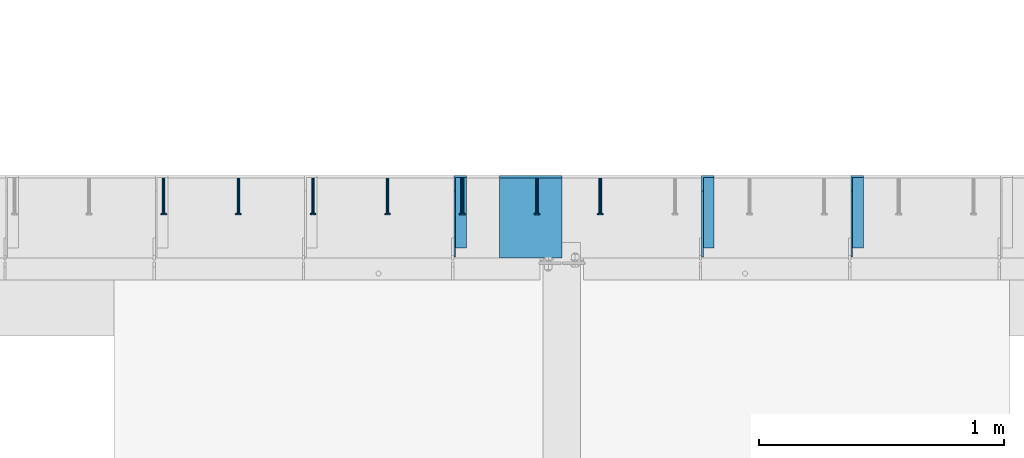
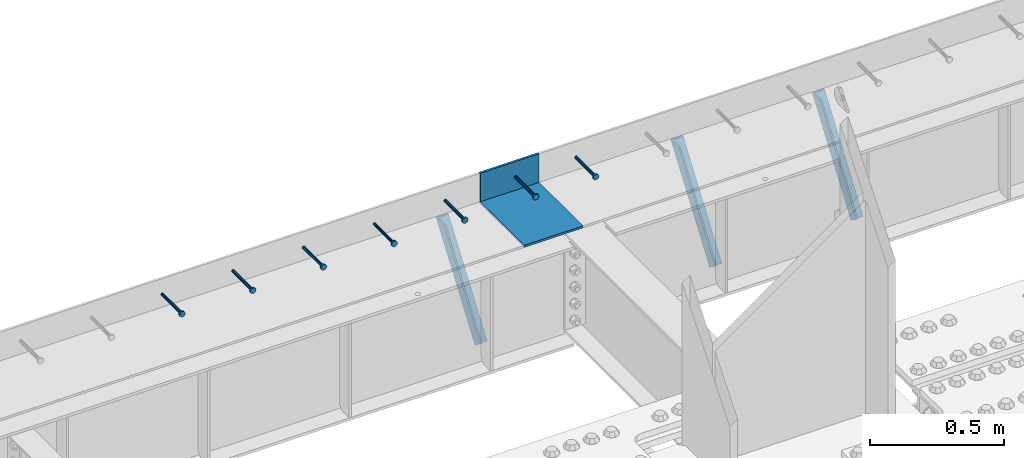
# One storey, part 1341 of 1763: 8 beams, 3 members, 9 elements without a shape of their own.
"""IFC2X3 building model written with IfcOpenShell, lengths in millimetres."""

from ifc_helpers import new_model, si_unit, frame, origin_with_axes, place, context, subcontext, project, spatial, faceted_brep, material, type_object, element, aggregate, save


model = new_model("IFC2X3")

# Units and contexts
model_context = context("Model", 3, precision=1e-05, world=origin_with_axes())
body_context = subcontext(model_context, "Body", "Model", "MODEL_VIEW")
ifc_project = project(units=[si_unit("LENGTHUNIT", "METRE", prefix="MILLI"), si_unit("AREAUNIT", "SQUARE_METRE"), si_unit("VOLUMEUNIT", "CUBIC_METRE"), si_unit("MASSUNIT", "GRAM", prefix="KILO"), si_unit("TIMEUNIT", "SECOND"), si_unit("PLANEANGLEUNIT", "RADIAN"), si_unit("SOLIDANGLEUNIT", "STERADIAN"), si_unit("THERMODYNAMICTEMPERATUREUNIT", "DEGREE_CELSIUS"), si_unit("LUMINOUSINTENSITYUNIT", "LUMEN")], contexts=[model_context])

# Site, building, storey
site_placement = place(None, origin_with_axes())
site = spatial("IfcSite", under=ifc_project, at=site_placement, CompositionType="ELEMENT")
building_placement = place(site_placement, origin_with_axes())
building = spatial("IfcBuilding", under=site, at=building_placement, Name="Undefined", CompositionType="ELEMENT")
storey_placement = place(building_placement, origin_with_axes())
storey = spatial("IfcBuildingStorey", under=building, at=storey_placement, Name="Undefined", CompositionType="ELEMENT", Elevation=0.0)

# Assembly, beam
assembly_1_placement = place(storey_placement, origin_with_axes())
assembly_1 = element("IfcElementAssembly", 1, at=assembly_1_placement, inside=storey, Name="HEADED STUD ANCHOR", AssemblyPlace="NOTDEFINED", PredefinedType="RIGID_FRAME")
ifc_material_1 = material(Name="STEEL/A108")
beam_type_1 = type_object("IfcBeamType", PredefinedType="NOTDEFINED")
beam_1_placement = place(assembly_1_placement, frame((-72333.8747736983, 53984.5250183106, 5264.23140606069), z_axis=(0.0, 0.0, 1.0), x_axis=(0.0, -1.0, 0.0)))
beam_1 = element("IfcBeam", 2, at=beam_1_placement, type_object=beam_type_1, material=ifc_material_1, Name="HEADED STUD ANCHOR", context=body_context, shape_type="Brep", body=[
    faceted_brep([(0.0, -3.1800000667572, 5.5), (0.0, -5.5, 3.1800000667572), (141.732000000002, -5.5, 3.1800000667572), (141.732000000002, -3.1800000667572, 5.5), (0.0, -6.34999999999491, 1.45519152283669e-11), (141.732000000002, -6.34999990463257, 0.0), (0.0, -5.5, -3.1800000667572), (141.732000000002, -5.5, -3.1800000667572), (0.0, -3.1800000667572, -5.5), (141.732000000002, -3.1800000667572, -5.5), (0.0, 0.0, -6.34999990463257), (141.732000000002, 0.0, -6.34999990463257), (0.0, 3.1800000667572, -5.5), (141.732000000002, 3.1800000667572, -5.5), (0.0, 5.5, -3.1800000667572), (141.732000000002, 5.5, -3.1800000667572), (0.0, 6.34999999999491, -2.91038304567337e-11), (141.732000000002, 6.34999990463257, 0.0), (0.0, 5.5, 3.1800000667572), (141.732000000002, 5.5, 3.1800000667572), (0.0, 3.1800000667572, 5.5), (141.732000000002, 3.1800000667572, 5.5), (0.0, 0.0, 6.34999990463257), (141.732000000002, 0.0, 6.34999990463257), (144.780000000001, -10.9899997711182, 6.34999990463257), (144.780000000001, -6.34000015258789, 10.9899997711182), (144.780000000001, -12.6999998092651, 0.0), (144.780000000001, -10.9899997711182, -6.34999990463257), (144.780000000001, -6.34000015258789, -10.9899997711182), (144.780000000001, 0.0, -12.6899995803833), (144.780000000001, 6.34000015258789, -10.9899997711182), (144.780000000001, 10.9899997711182, -6.34999990463257), (144.780000000001, 12.6999998092651, 0.0), (144.780000000001, 10.9899997711182, 6.34999990463257), (144.780000000001, 6.34000015258789, 10.9899997711182), (144.780000000001, 0.0, 12.6899995803833), (152.400000000001, -10.9899997711182, 6.34999990463257), (152.400000000001, -6.34000015258789, 10.9899997711182), (152.400000000001, -12.6999998092651, 0.0), (152.400000000001, -10.9899997711182, -6.34999990463257), (152.400000000001, -6.34000015258789, -10.9899997711182), (152.400000000001, 0.0, -12.6899995803833), (152.400000000001, 6.34000015258789, -10.9899997711182), (152.400000000001, 10.9899997711182, -6.34999990463257), (152.400000000001, 12.6999998092651, 0.0), (152.400000000001, 10.9899997711182, 6.34999990463257), (152.400000000001, 6.34000015258789, 10.9899997711182), (152.400000000001, 0.0, 12.6899995803833)], [[[0, 1, 2, 3]], [[1, 4, 5, 2]], [[4, 6, 7, 5]], [[6, 8, 9, 7]], [[8, 10, 11, 9]], [[10, 12, 13, 11]], [[12, 14, 15, 13]], [[14, 16, 17, 15]], [[16, 18, 19, 17]], [[18, 20, 21, 19]], [[20, 22, 23, 21]], [[22, 0, 3, 23]], [[22, 20, 18, 16, 14, 12, 10, 8, 6, 4, 1, 0]], [[3, 2, 24, 25]], [[2, 5, 26, 24]], [[5, 7, 27, 26]], [[7, 9, 28, 27]], [[9, 11, 29, 28]], [[11, 13, 30, 29]], [[13, 15, 31, 30]], [[15, 17, 32, 31]], [[17, 19, 33, 32]], [[19, 21, 34, 33]], [[21, 23, 35, 34]], [[23, 3, 25, 35]], [[25, 24, 36, 37]], [[24, 26, 38, 36]], [[26, 27, 39, 38]], [[27, 28, 40, 39]], [[28, 29, 41, 40]], [[29, 30, 42, 41]], [[30, 31, 43, 42]], [[31, 32, 44, 43]], [[32, 33, 45, 44]], [[33, 34, 46, 45]], [[34, 35, 47, 46]], [[35, 25, 37, 47]], [[38, 39, 40, 41, 42, 43, 44, 45, 46, 47, 37, 36]]]),
])
aggregate(assembly_1, [beam_1])

assembly_2_placement = place(storey_placement, origin_with_axes())
assembly_2 = element("IfcElementAssembly", 3, at=assembly_2_placement, inside=storey, Name="HEADED STUD ANCHOR", AssemblyPlace="NOTDEFINED", PredefinedType="RIGID_FRAME")
beam_2_placement = place(assembly_2_placement, frame((-72592.6372736983, 53984.5250183106, 5264.23140606069), z_axis=(0.0, 0.0, 1.0), x_axis=(0.0, -1.0, 0.0)))
beam_2 = element("IfcBeam", 4, at=beam_2_placement, type_object=beam_type_1, material=ifc_material_1, Name="HEADED STUD ANCHOR", context=body_context, shape_type="Brep", body=[
    faceted_brep([(0.0, -3.1800000667572, 5.5), (0.0, -5.5, 3.1800000667572), (141.732000000002, -5.5, 3.1800000667572), (141.732000000002, -3.1800000667572, 5.5), (0.0, -6.34999999999491, 1.45519152283669e-11), (141.732000000002, -6.34999990463257, 0.0), (0.0, -5.5, -3.1800000667572), (141.732000000002, -5.5, -3.1800000667572), (0.0, -3.1800000667572, -5.5), (141.732000000002, -3.1800000667572, -5.5), (0.0, 0.0, -6.34999990463257), (141.732000000002, 0.0, -6.34999990463257), (0.0, 3.1800000667572, -5.5), (141.732000000002, 3.1800000667572, -5.5), (0.0, 5.5, -3.1800000667572), (141.732000000002, 5.5, -3.1800000667572), (0.0, 6.34999999999491, -2.91038304567337e-11), (141.732000000002, 6.34999990463257, 0.0), (0.0, 5.5, 3.1800000667572), (141.732000000002, 5.5, 3.1800000667572), (0.0, 3.1800000667572, 5.5), (141.732000000002, 3.1800000667572, 5.5), (0.0, 0.0, 6.34999990463257), (141.732000000002, 0.0, 6.34999990463257), (144.780000000001, -10.9899997711182, 6.34999990463257), (144.780000000001, -6.34000015258789, 10.9899997711182), (144.780000000001, -12.6999998092651, 0.0), (144.780000000001, -10.9899997711182, -6.34999990463257), (144.780000000001, -6.34000015258789, -10.9899997711182), (144.780000000001, 0.0, -12.6899995803833), (144.780000000001, 6.34000015258789, -10.9899997711182), (144.780000000001, 10.9899997711182, -6.34999990463257), (144.780000000001, 12.6999998092651, 0.0), (144.780000000001, 10.9899997711182, 6.34999990463257), (144.780000000001, 6.34000015258789, 10.9899997711182), (144.780000000001, 0.0, 12.6899995803833), (152.400000000001, -10.9899997711182, 6.34999990463257), (152.400000000001, -6.34000015258789, 10.9899997711182), (152.400000000001, -12.6999998092651, 0.0), (152.400000000001, -10.9899997711182, -6.34999990463257), (152.400000000001, -6.34000015258789, -10.9899997711182), (152.400000000001, 0.0, -12.6899995803833), (152.400000000001, 6.34000015258789, -10.9899997711182), (152.400000000001, 10.9899997711182, -6.34999990463257), (152.400000000001, 12.6999998092651, 0.0), (152.400000000001, 10.9899997711182, 6.34999990463257), (152.400000000001, 6.34000015258789, 10.9899997711182), (152.400000000001, 0.0, 12.6899995803833)], [[[0, 1, 2, 3]], [[1, 4, 5, 2]], [[4, 6, 7, 5]], [[6, 8, 9, 7]], [[8, 10, 11, 9]], [[10, 12, 13, 11]], [[12, 14, 15, 13]], [[14, 16, 17, 15]], [[16, 18, 19, 17]], [[18, 20, 21, 19]], [[20, 22, 23, 21]], [[22, 0, 3, 23]], [[22, 20, 18, 16, 14, 12, 10, 8, 6, 4, 1, 0]], [[3, 2, 24, 25]], [[2, 5, 26, 24]], [[5, 7, 27, 26]], [[7, 9, 28, 27]], [[9, 11, 29, 28]], [[11, 13, 30, 29]], [[13, 15, 31, 30]], [[15, 17, 32, 31]], [[17, 19, 33, 32]], [[19, 21, 34, 33]], [[21, 23, 35, 34]], [[23, 3, 25, 35]], [[25, 24, 36, 37]], [[24, 26, 38, 36]], [[26, 27, 39, 38]], [[27, 28, 40, 39]], [[28, 29, 41, 40]], [[29, 30, 42, 41]], [[30, 31, 43, 42]], [[31, 32, 44, 43]], [[32, 33, 45, 44]], [[33, 34, 46, 45]], [[34, 35, 47, 46]], [[35, 25, 37, 47]], [[38, 39, 40, 41, 42, 43, 44, 45, 46, 47, 37, 36]]]),
])
aggregate(assembly_2, [beam_2])

assembly_3_placement = place(storey_placement, origin_with_axes())
assembly_3 = element("IfcElementAssembly", 5, at=assembly_3_placement, inside=storey, Name="HEADED STUD ANCHOR", AssemblyPlace="NOTDEFINED", PredefinedType="RIGID_FRAME")
beam_3_placement = place(assembly_3_placement, frame((-72897.4372736983, 53984.5250183106, 5264.23140606069), z_axis=(0.0, 0.0, 1.0), x_axis=(0.0, -1.0, 0.0)))
beam_3 = element("IfcBeam", 6, at=beam_3_placement, type_object=beam_type_1, material=ifc_material_1, Name="HEADED STUD ANCHOR", context=body_context, shape_type="Brep", body=[
    faceted_brep([(0.0, -3.1800000667572, 5.5), (0.0, -5.5, 3.1800000667572), (141.732000000002, -5.5, 3.1800000667572), (141.732000000002, -3.1800000667572, 5.5), (0.0, -6.34999999999491, 1.45519152283669e-11), (141.732000000002, -6.34999990463257, 0.0), (0.0, -5.5, -3.1800000667572), (141.732000000002, -5.5, -3.1800000667572), (0.0, -3.1800000667572, -5.5), (141.732000000002, -3.1800000667572, -5.5), (0.0, 0.0, -6.34999990463257), (141.732000000002, 0.0, -6.34999990463257), (0.0, 3.1800000667572, -5.5), (141.732000000002, 3.1800000667572, -5.5), (0.0, 5.5, -3.1800000667572), (141.732000000002, 5.5, -3.1800000667572), (0.0, 6.34999999999491, -2.91038304567337e-11), (141.732000000002, 6.34999990463257, 0.0), (0.0, 5.5, 3.1800000667572), (141.732000000002, 5.5, 3.1800000667572), (0.0, 3.1800000667572, 5.5), (141.732000000002, 3.1800000667572, 5.5), (0.0, 0.0, 6.34999990463257), (141.732000000002, 0.0, 6.34999990463257), (144.780000000001, -10.9899997711182, 6.34999990463257), (144.780000000001, -6.34000015258789, 10.9899997711182), (144.780000000001, -12.6999998092651, 0.0), (144.780000000001, -10.9899997711182, -6.34999990463257), (144.780000000001, -6.34000015258789, -10.9899997711182), (144.780000000001, 0.0, -12.6899995803833), (144.780000000001, 6.34000015258789, -10.9899997711182), (144.780000000001, 10.9899997711182, -6.34999990463257), (144.780000000001, 12.6999998092651, 0.0), (144.780000000001, 10.9899997711182, 6.34999990463257), (144.780000000001, 6.34000015258789, 10.9899997711182), (144.780000000001, 0.0, 12.6899995803833), (152.400000000001, -10.9899997711182, 6.34999990463257), (152.400000000001, -6.34000015258789, 10.9899997711182), (152.400000000001, -12.6999998092651, 0.0), (152.400000000001, -10.9899997711182, -6.34999990463257), (152.400000000001, -6.34000015258789, -10.9899997711182), (152.400000000001, 0.0, -12.6899995803833), (152.400000000001, 6.34000015258789, -10.9899997711182), (152.400000000001, 10.9899997711182, -6.34999990463257), (152.400000000001, 12.6999998092651, 0.0), (152.400000000001, 10.9899997711182, 6.34999990463257), (152.400000000001, 6.34000015258789, 10.9899997711182), (152.400000000001, 0.0, 12.6899995803833)], [[[0, 1, 2, 3]], [[1, 4, 5, 2]], [[4, 6, 7, 5]], [[6, 8, 9, 7]], [[8, 10, 11, 9]], [[10, 12, 13, 11]], [[12, 14, 15, 13]], [[14, 16, 17, 15]], [[16, 18, 19, 17]], [[18, 20, 21, 19]], [[20, 22, 23, 21]], [[22, 0, 3, 23]], [[22, 20, 18, 16, 14, 12, 10, 8, 6, 4, 1, 0]], [[3, 2, 24, 25]], [[2, 5, 26, 24]], [[5, 7, 27, 26]], [[7, 9, 28, 27]], [[9, 11, 29, 28]], [[11, 13, 30, 29]], [[13, 15, 31, 30]], [[15, 17, 32, 31]], [[17, 19, 33, 32]], [[19, 21, 34, 33]], [[21, 23, 35, 34]], [[23, 3, 25, 35]], [[25, 24, 36, 37]], [[24, 26, 38, 36]], [[26, 27, 39, 38]], [[27, 28, 40, 39]], [[28, 29, 41, 40]], [[29, 30, 42, 41]], [[30, 31, 43, 42]], [[31, 32, 44, 43]], [[32, 33, 45, 44]], [[33, 34, 46, 45]], [[34, 35, 47, 46]], [[35, 25, 37, 47]], [[38, 39, 40, 41, 42, 43, 44, 45, 46, 47, 37, 36]]]),
])
aggregate(assembly_3, [beam_3])

assembly_4_placement = place(storey_placement, origin_with_axes())
assembly_4 = element("IfcElementAssembly", 7, at=assembly_4_placement, inside=storey, Name="HEADED STUD ANCHOR", AssemblyPlace="NOTDEFINED", PredefinedType="RIGID_FRAME")
beam_4_placement = place(assembly_4_placement, frame((-73202.2372736984, 53984.5250183106, 5264.23140606069), z_axis=(0.0, 0.0, 1.0), x_axis=(0.0, -1.0, 0.0)))
beam_4 = element("IfcBeam", 8, at=beam_4_placement, type_object=beam_type_1, material=ifc_material_1, Name="HEADED STUD ANCHOR", context=body_context, shape_type="Brep", body=[
    faceted_brep([(0.0, -3.1800000667572, 5.5), (0.0, -5.5, 3.1800000667572), (141.732000000002, -5.5, 3.1800000667572), (141.732000000002, -3.1800000667572, 5.5), (0.0, -6.34999999999491, 1.45519152283669e-11), (141.732000000002, -6.34999990463257, 0.0), (0.0, -5.5, -3.1800000667572), (141.732000000002, -5.5, -3.1800000667572), (0.0, -3.1800000667572, -5.5), (141.732000000002, -3.1800000667572, -5.5), (0.0, 0.0, -6.34999990463257), (141.732000000002, 0.0, -6.34999990463257), (0.0, 3.1800000667572, -5.5), (141.732000000002, 3.1800000667572, -5.5), (0.0, 5.5, -3.1800000667572), (141.732000000002, 5.5, -3.1800000667572), (0.0, 6.34999999999491, -2.91038304567337e-11), (141.732000000002, 6.34999990463257, 0.0), (0.0, 5.5, 3.1800000667572), (141.732000000002, 5.5, 3.1800000667572), (0.0, 3.1800000667572, 5.5), (141.732000000002, 3.1800000667572, 5.5), (0.0, 0.0, 6.34999990463257), (141.732000000002, 0.0, 6.34999990463257), (144.780000000001, -10.9899997711182, 6.34999990463257), (144.780000000001, -6.34000015258789, 10.9899997711182), (144.780000000001, -12.6999998092651, 0.0), (144.780000000001, -10.9899997711182, -6.34999990463257), (144.780000000001, -6.34000015258789, -10.9899997711182), (144.780000000001, 0.0, -12.6899995803833), (144.780000000001, 6.34000015258789, -10.9899997711182), (144.780000000001, 10.9899997711182, -6.34999990463257), (144.780000000001, 12.6999998092651, 0.0), (144.780000000001, 10.9899997711182, 6.34999990463257), (144.780000000001, 6.34000015258789, 10.9899997711182), (144.780000000001, 0.0, 12.6899995803833), (152.400000000001, -10.9899997711182, 6.34999990463257), (152.400000000001, -6.34000015258789, 10.9899997711182), (152.400000000001, -12.6999998092651, 0.0), (152.400000000001, -10.9899997711182, -6.34999990463257), (152.400000000001, -6.34000015258789, -10.9899997711182), (152.400000000001, 0.0, -12.6899995803833), (152.400000000001, 6.34000015258789, -10.9899997711182), (152.400000000001, 10.9899997711182, -6.34999990463257), (152.400000000001, 12.6999998092651, 0.0), (152.400000000001, 10.9899997711182, 6.34999990463257), (152.400000000001, 6.34000015258789, 10.9899997711182), (152.400000000001, 0.0, 12.6899995803833)], [[[0, 1, 2, 3]], [[1, 4, 5, 2]], [[4, 6, 7, 5]], [[6, 8, 9, 7]], [[8, 10, 11, 9]], [[10, 12, 13, 11]], [[12, 14, 15, 13]], [[14, 16, 17, 15]], [[16, 18, 19, 17]], [[18, 20, 21, 19]], [[20, 22, 23, 21]], [[22, 0, 3, 23]], [[22, 20, 18, 16, 14, 12, 10, 8, 6, 4, 1, 0]], [[3, 2, 24, 25]], [[2, 5, 26, 24]], [[5, 7, 27, 26]], [[7, 9, 28, 27]], [[9, 11, 29, 28]], [[11, 13, 30, 29]], [[13, 15, 31, 30]], [[15, 17, 32, 31]], [[17, 19, 33, 32]], [[19, 21, 34, 33]], [[21, 23, 35, 34]], [[23, 3, 25, 35]], [[25, 24, 36, 37]], [[24, 26, 38, 36]], [[26, 27, 39, 38]], [[27, 28, 40, 39]], [[28, 29, 41, 40]], [[29, 30, 42, 41]], [[30, 31, 43, 42]], [[31, 32, 44, 43]], [[32, 33, 45, 44]], [[33, 34, 46, 45]], [[34, 35, 47, 46]], [[35, 25, 37, 47]], [[38, 39, 40, 41, 42, 43, 44, 45, 46, 47, 37, 36]]]),
])
aggregate(assembly_4, [beam_4])

assembly_5_placement = place(storey_placement, origin_with_axes())
assembly_5 = element("IfcElementAssembly", 9, at=assembly_5_placement, inside=storey, Name="HEADED STUD ANCHOR", AssemblyPlace="NOTDEFINED", PredefinedType="RIGID_FRAME")
beam_5_placement = place(assembly_5_placement, frame((-73507.0372736983, 53984.5250183106, 5264.23140606069), z_axis=(0.0, 0.0, 1.0), x_axis=(0.0, -1.0, 0.0)))
beam_5 = element("IfcBeam", 10, at=beam_5_placement, type_object=beam_type_1, material=ifc_material_1, Name="HEADED STUD ANCHOR", context=body_context, shape_type="Brep", body=[
    faceted_brep([(0.0, -3.1800000667572, 5.5), (0.0, -5.5, 3.1800000667572), (141.732000000002, -5.5, 3.1800000667572), (141.732000000002, -3.1800000667572, 5.5), (0.0, -6.34999999999491, 1.45519152283669e-11), (141.732000000002, -6.34999990463257, 0.0), (0.0, -5.5, -3.1800000667572), (141.732000000002, -5.5, -3.1800000667572), (0.0, -3.1800000667572, -5.5), (141.732000000002, -3.1800000667572, -5.5), (0.0, 0.0, -6.34999990463257), (141.732000000002, 0.0, -6.34999990463257), (0.0, 3.1800000667572, -5.5), (141.732000000002, 3.1800000667572, -5.5), (0.0, 5.5, -3.1800000667572), (141.732000000002, 5.5, -3.1800000667572), (0.0, 6.34999999999491, -2.91038304567337e-11), (141.732000000002, 6.34999990463257, 0.0), (0.0, 5.5, 3.1800000667572), (141.732000000002, 5.5, 3.1800000667572), (0.0, 3.1800000667572, 5.5), (141.732000000002, 3.1800000667572, 5.5), (0.0, 0.0, 6.34999990463257), (141.732000000002, 0.0, 6.34999990463257), (144.780000000001, -10.9899997711182, 6.34999990463257), (144.780000000001, -6.34000015258789, 10.9899997711182), (144.780000000001, -12.6999998092651, 0.0), (144.780000000001, -10.9899997711182, -6.34999990463257), (144.780000000001, -6.34000015258789, -10.9899997711182), (144.780000000001, 0.0, -12.6899995803833), (144.780000000001, 6.34000015258789, -10.9899997711182), (144.780000000001, 10.9899997711182, -6.34999990463257), (144.780000000001, 12.6999998092651, 0.0), (144.780000000001, 10.9899997711182, 6.34999990463257), (144.780000000001, 6.34000015258789, 10.9899997711182), (144.780000000001, 0.0, 12.6899995803833), (152.400000000001, -10.9899997711182, 6.34999990463257), (152.400000000001, -6.34000015258789, 10.9899997711182), (152.400000000001, -12.6999998092651, 0.0), (152.400000000001, -10.9899997711182, -6.34999990463257), (152.400000000001, -6.34000015258789, -10.9899997711182), (152.400000000001, 0.0, -12.6899995803833), (152.400000000001, 6.34000015258789, -10.9899997711182), (152.400000000001, 10.9899997711182, -6.34999990463257), (152.400000000001, 12.6999998092651, 0.0), (152.400000000001, 10.9899997711182, 6.34999990463257), (152.400000000001, 6.34000015258789, 10.9899997711182), (152.400000000001, 0.0, 12.6899995803833)], [[[0, 1, 2, 3]], [[1, 4, 5, 2]], [[4, 6, 7, 5]], [[6, 8, 9, 7]], [[8, 10, 11, 9]], [[10, 12, 13, 11]], [[12, 14, 15, 13]], [[14, 16, 17, 15]], [[16, 18, 19, 17]], [[18, 20, 21, 19]], [[20, 22, 23, 21]], [[22, 0, 3, 23]], [[22, 20, 18, 16, 14, 12, 10, 8, 6, 4, 1, 0]], [[3, 2, 24, 25]], [[2, 5, 26, 24]], [[5, 7, 27, 26]], [[7, 9, 28, 27]], [[9, 11, 29, 28]], [[11, 13, 30, 29]], [[13, 15, 31, 30]], [[15, 17, 32, 31]], [[17, 19, 33, 32]], [[19, 21, 34, 33]], [[21, 23, 35, 34]], [[23, 3, 25, 35]], [[25, 24, 36, 37]], [[24, 26, 38, 36]], [[26, 27, 39, 38]], [[27, 28, 40, 39]], [[28, 29, 41, 40]], [[29, 30, 42, 41]], [[30, 31, 43, 42]], [[31, 32, 44, 43]], [[32, 33, 45, 44]], [[33, 34, 46, 45]], [[34, 35, 47, 46]], [[35, 25, 37, 47]], [[38, 39, 40, 41, 42, 43, 44, 45, 46, 47, 37, 36]]]),
])
aggregate(assembly_5, [beam_5])

assembly_6_placement = place(storey_placement, origin_with_axes())
assembly_6 = element("IfcElementAssembly", 11, at=assembly_6_placement, inside=storey, Name="HEADED STUD ANCHOR", AssemblyPlace="NOTDEFINED", PredefinedType="RIGID_FRAME")
beam_6_placement = place(assembly_6_placement, frame((-73811.8372736983, 53984.5250183106, 5264.23140606069), z_axis=(0.0, 0.0, 1.0), x_axis=(0.0, -1.0, 0.0)))
beam_6 = element("IfcBeam", 12, at=beam_6_placement, type_object=beam_type_1, material=ifc_material_1, Name="HEADED STUD ANCHOR", context=body_context, shape_type="Brep", body=[
    faceted_brep([(0.0, -3.1800000667572, 5.5), (0.0, -5.5, 3.1800000667572), (141.732000000002, -5.5, 3.1800000667572), (141.732000000002, -3.1800000667572, 5.5), (0.0, -6.34999999999491, 1.45519152283669e-11), (141.732000000002, -6.34999990463257, 0.0), (0.0, -5.5, -3.1800000667572), (141.732000000002, -5.5, -3.1800000667572), (0.0, -3.1800000667572, -5.5), (141.732000000002, -3.1800000667572, -5.5), (0.0, 0.0, -6.34999990463257), (141.732000000002, 0.0, -6.34999990463257), (0.0, 3.1800000667572, -5.5), (141.732000000002, 3.1800000667572, -5.5), (0.0, 5.5, -3.1800000667572), (141.732000000002, 5.5, -3.1800000667572), (0.0, 6.34999999999491, -2.91038304567337e-11), (141.732000000002, 6.34999990463257, 0.0), (0.0, 5.5, 3.1800000667572), (141.732000000002, 5.5, 3.1800000667572), (0.0, 3.1800000667572, 5.5), (141.732000000002, 3.1800000667572, 5.5), (0.0, 0.0, 6.34999990463257), (141.732000000002, 0.0, 6.34999990463257), (144.780000000001, -10.9899997711182, 6.34999990463257), (144.780000000001, -6.34000015258789, 10.9899997711182), (144.780000000001, -12.6999998092651, 0.0), (144.780000000001, -10.9899997711182, -6.34999990463257), (144.780000000001, -6.34000015258789, -10.9899997711182), (144.780000000001, 0.0, -12.6899995803833), (144.780000000001, 6.34000015258789, -10.9899997711182), (144.780000000001, 10.9899997711182, -6.34999990463257), (144.780000000001, 12.6999998092651, 0.0), (144.780000000001, 10.9899997711182, 6.34999990463257), (144.780000000001, 6.34000015258789, 10.9899997711182), (144.780000000001, 0.0, 12.6899995803833), (152.400000000001, -10.9899997711182, 6.34999990463257), (152.400000000001, -6.34000015258789, 10.9899997711182), (152.400000000001, -12.6999998092651, 0.0), (152.400000000001, -10.9899997711182, -6.34999990463257), (152.400000000001, -6.34000015258789, -10.9899997711182), (152.400000000001, 0.0, -12.6899995803833), (152.400000000001, 6.34000015258789, -10.9899997711182), (152.400000000001, 10.9899997711182, -6.34999990463257), (152.400000000001, 12.6999998092651, 0.0), (152.400000000001, 10.9899997711182, 6.34999990463257), (152.400000000001, 6.34000015258789, 10.9899997711182), (152.400000000001, 0.0, 12.6899995803833)], [[[0, 1, 2, 3]], [[1, 4, 5, 2]], [[4, 6, 7, 5]], [[6, 8, 9, 7]], [[8, 10, 11, 9]], [[10, 12, 13, 11]], [[12, 14, 15, 13]], [[14, 16, 17, 15]], [[16, 18, 19, 17]], [[18, 20, 21, 19]], [[20, 22, 23, 21]], [[22, 0, 3, 23]], [[22, 20, 18, 16, 14, 12, 10, 8, 6, 4, 1, 0]], [[3, 2, 24, 25]], [[2, 5, 26, 24]], [[5, 7, 27, 26]], [[7, 9, 28, 27]], [[9, 11, 29, 28]], [[11, 13, 30, 29]], [[13, 15, 31, 30]], [[15, 17, 32, 31]], [[17, 19, 33, 32]], [[19, 21, 34, 33]], [[21, 23, 35, 34]], [[23, 3, 25, 35]], [[25, 24, 36, 37]], [[24, 26, 38, 36]], [[26, 27, 39, 38]], [[27, 28, 40, 39]], [[28, 29, 41, 40]], [[29, 30, 42, 41]], [[30, 31, 43, 42]], [[31, 32, 44, 43]], [[32, 33, 45, 44]], [[33, 34, 46, 45]], [[34, 35, 47, 46]], [[35, 25, 37, 47]], [[38, 39, 40, 41, 42, 43, 44, 45, 46, 47, 37, 36]]]),
])
aggregate(assembly_6, [beam_6])

assembly_7_placement = place(storey_placement, origin_with_axes())
assembly_7 = element("IfcElementAssembly", 13, at=assembly_7_placement, inside=storey, Name="HEADED STUD ANCHOR", AssemblyPlace="NOTDEFINED", PredefinedType="RIGID_FRAME")
beam_7_placement = place(assembly_7_placement, frame((-74116.6372736983, 53984.5250183106, 5264.23140606069), z_axis=(0.0, 0.0, 1.0), x_axis=(0.0, -1.0, 0.0)))
beam_7 = element("IfcBeam", 14, at=beam_7_placement, type_object=beam_type_1, material=ifc_material_1, Name="HEADED STUD ANCHOR", context=body_context, shape_type="Brep", body=[
    faceted_brep([(0.0, -3.1800000667572, 5.5), (0.0, -5.5, 3.1800000667572), (141.732000000002, -5.5, 3.1800000667572), (141.732000000002, -3.1800000667572, 5.5), (0.0, -6.34999999999491, 1.45519152283669e-11), (141.732000000002, -6.34999990463257, 0.0), (0.0, -5.5, -3.1800000667572), (141.732000000002, -5.5, -3.1800000667572), (0.0, -3.1800000667572, -5.5), (141.732000000002, -3.1800000667572, -5.5), (0.0, 0.0, -6.34999990463257), (141.732000000002, 0.0, -6.34999990463257), (0.0, 3.1800000667572, -5.5), (141.732000000002, 3.1800000667572, -5.5), (0.0, 5.5, -3.1800000667572), (141.732000000002, 5.5, -3.1800000667572), (0.0, 6.34999999999491, -2.91038304567337e-11), (141.732000000002, 6.34999990463257, 0.0), (0.0, 5.5, 3.1800000667572), (141.732000000002, 5.5, 3.1800000667572), (0.0, 3.1800000667572, 5.5), (141.732000000002, 3.1800000667572, 5.5), (0.0, 0.0, 6.34999990463257), (141.732000000002, 0.0, 6.34999990463257), (144.780000000001, -10.9899997711182, 6.34999990463257), (144.780000000001, -6.34000015258789, 10.9899997711182), (144.780000000001, -12.6999998092651, 0.0), (144.780000000001, -10.9899997711182, -6.34999990463257), (144.780000000001, -6.34000015258789, -10.9899997711182), (144.780000000001, 0.0, -12.6899995803833), (144.780000000001, 6.34000015258789, -10.9899997711182), (144.780000000001, 10.9899997711182, -6.34999990463257), (144.780000000001, 12.6999998092651, 0.0), (144.780000000001, 10.9899997711182, 6.34999990463257), (144.780000000001, 6.34000015258789, 10.9899997711182), (144.780000000001, 0.0, 12.6899995803833), (152.400000000001, -10.9899997711182, 6.34999990463257), (152.400000000001, -6.34000015258789, 10.9899997711182), (152.400000000001, -12.6999998092651, 0.0), (152.400000000001, -10.9899997711182, -6.34999990463257), (152.400000000001, -6.34000015258789, -10.9899997711182), (152.400000000001, 0.0, -12.6899995803833), (152.400000000001, 6.34000015258789, -10.9899997711182), (152.400000000001, 10.9899997711182, -6.34999990463257), (152.400000000001, 12.6999998092651, 0.0), (152.400000000001, 10.9899997711182, 6.34999990463257), (152.400000000001, 6.34000015258789, 10.9899997711182), (152.400000000001, 0.0, 12.6899995803833)], [[[0, 1, 2, 3]], [[1, 4, 5, 2]], [[4, 6, 7, 5]], [[6, 8, 9, 7]], [[8, 10, 11, 9]], [[10, 12, 13, 11]], [[12, 14, 15, 13]], [[14, 16, 17, 15]], [[16, 18, 19, 17]], [[18, 20, 21, 19]], [[20, 22, 23, 21]], [[22, 0, 3, 23]], [[22, 20, 18, 16, 14, 12, 10, 8, 6, 4, 1, 0]], [[3, 2, 24, 25]], [[2, 5, 26, 24]], [[5, 7, 27, 26]], [[7, 9, 28, 27]], [[9, 11, 29, 28]], [[11, 13, 30, 29]], [[13, 15, 31, 30]], [[15, 17, 32, 31]], [[17, 19, 33, 32]], [[19, 21, 34, 33]], [[21, 23, 35, 34]], [[23, 3, 25, 35]], [[25, 24, 36, 37]], [[24, 26, 38, 36]], [[26, 27, 39, 38]], [[27, 28, 40, 39]], [[28, 29, 41, 40]], [[29, 30, 42, 41]], [[30, 31, 43, 42]], [[31, 32, 44, 43]], [[32, 33, 45, 44]], [[33, 34, 46, 45]], [[34, 35, 47, 46]], [[35, 25, 37, 47]], [[38, 39, 40, 41, 42, 43, 44, 45, 46, 47, 37, 36]]]),
])
aggregate(assembly_7, [beam_7])

# Assembly, members
assembly_8_placement = place(storey_placement, origin_with_axes())
assembly_8 = element("IfcElementAssembly", 15, at=assembly_8_placement, inside=storey, Name="BEAM", AssemblyPlace="NOTDEFINED", PredefinedType="RIGID_FRAME")
ifc_material_2 = material(Name="STEEL/A36")
member_type = type_object("IfcMemberType", Name="L2X2X1/4", PredefinedType="NOTDEFINED")
member_1_placement = place(assembly_8_placement, frame((-71284.5372736984, 53682.7083833994, 4801.55161052496), z_axis=(0.0, -0.814117947745209, 0.580699549818259), x_axis=(0.0, 0.58069954981826, 0.814117947745209)))
member_1 = element("IfcMember", 16, at=member_1_placement, type_object=member_type, material=ifc_material_2, Name="ANGLE", ObjectType="L2X2X1/4", context=body_context, shape_type="Brep", body=[
    faceted_brep([(-1.45519152283669e-11, 25.4000000000015, -25.3999999999869), (1.45519152283669e-11, 25.4000000000015, 25.3999999999796), (464.304493432646, 25.4000000000015, 25.3999999991429), (500.539460322936, 25.4000000000015, -25.4000000009546), (1.45519152283669e-11, 19.0499999999993, 25.3999999999796), (464.304493432646, 19.0500000000029, 25.3999999991429), (-7.27595761418343e-12, 19.0499999999993, -19.0499999999956), (496.010089461648, 19.0500000000029, -19.0500000009415), (-7.27595761418343e-12, -25.4000000000015, -19.0499999999956), (496.010089461648, -25.4000000000015, -19.0500000009415), (-1.45519152283669e-11, -25.4000000000015, -25.3999999999869), (500.539460322936, -25.4000000000015, -25.4000000009546)], [[[0, 1, 2, 3]], [[1, 4, 5, 2]], [[4, 6, 7, 5]], [[6, 8, 9, 7]], [[8, 10, 11, 9]], [[10, 0, 3, 11]], [[5, 7, 9, 11, 3, 2]], [[10, 8, 6, 4, 1, 0]]]),
])
member_2_placement = place(assembly_8_placement, frame((-71894.1372736984, 53682.7083833994, 4801.55161052496), z_axis=(0.0, -0.814117947745209, 0.580699549818259), x_axis=(0.0, 0.58069954981826, 0.814117947745209)))
member_2 = element("IfcMember", 17, at=member_2_placement, type_object=member_type, material=ifc_material_2, Name="ANGLE", ObjectType="L2X2X1/4", context=body_context, shape_type="Brep", body=[
    faceted_brep([(-1.45519152283669e-11, 25.4000000000015, -25.3999999999869), (1.45519152283669e-11, 25.4000000000015, 25.3999999999796), (464.304493432646, 25.4000000000015, 25.3999999991429), (500.539460322936, 25.4000000000015, -25.4000000009546), (1.45519152283669e-11, 19.0499999999993, 25.3999999999796), (464.304493432646, 19.0500000000029, 25.3999999991429), (-7.27595761418343e-12, 19.0499999999993, -19.0499999999956), (496.010089461648, 19.0500000000029, -19.0500000009415), (-7.27595761418343e-12, -25.4000000000015, -19.0499999999956), (496.010089461648, -25.4000000000015, -19.0500000009415), (-1.45519152283669e-11, -25.4000000000015, -25.3999999999869), (500.539460322936, -25.4000000000015, -25.4000000009546)], [[[0, 1, 2, 3]], [[1, 4, 5, 2]], [[4, 6, 7, 5]], [[6, 8, 9, 7]], [[8, 10, 11, 9]], [[10, 0, 3, 11]], [[5, 7, 9, 11, 3, 2]], [[10, 8, 6, 4, 1, 0]]]),
])
aggregate(assembly_8, [member_1, member_2])

# Assembly, member, beam
assembly_9_placement = place(storey_placement, origin_with_axes())
assembly_9 = element("IfcElementAssembly", 18, at=assembly_9_placement, inside=storey, Name="BEAM", AssemblyPlace="NOTDEFINED", PredefinedType="RIGID_FRAME")
member_3_placement = place(assembly_9_placement, frame((-72905.7716486984, 53682.7083833994, 4801.55161052494), z_axis=(0.0, -0.814117947745209, 0.580699549818259), x_axis=(0.0, 0.58069954981826, 0.814117947745209)))
member_3 = element("IfcMember", 19, at=member_3_placement, type_object=member_type, material=ifc_material_2, Name="ANGLE", ObjectType="L2X2X1/4", context=body_context, shape_type="Brep", body=[
    faceted_brep([(-1.45519152283669e-11, 25.4000000000015, -25.3999999999869), (1.45519152283669e-11, 25.4000000000015, 25.3999999999796), (464.304493432646, 25.4000000000015, 25.3999999991429), (500.539460322936, 25.4000000000015, -25.4000000009546), (1.45519152283669e-11, 19.0499999999993, 25.3999999999796), (464.304493432646, 19.0500000000029, 25.3999999991429), (-7.27595761418343e-12, 19.0499999999993, -19.0499999999956), (496.010089461648, 19.0500000000029, -19.0500000009415), (-7.27595761418343e-12, -25.4000000000015, -19.0499999999956), (496.010089461648, -25.4000000000015, -19.0500000009415), (-1.45519152283669e-11, -25.4000000000015, -25.3999999999869), (500.539460322936, -25.4000000000015, -25.4000000009546)], [[[0, 1, 2, 3]], [[1, 4, 5, 2]], [[4, 6, 7, 5]], [[6, 8, 9, 7]], [[8, 10, 11, 9]], [[10, 0, 3, 11]], [[5, 7, 9, 11, 3, 2]], [[10, 8, 6, 4, 1, 0]]]),
])
beam_type_2 = type_object("IfcBeamType", PredefinedType="NOTDEFINED")
beam_8_placement = place(assembly_9_placement, frame((-72618.0372736984, 53657.5, 5199.0625), z_axis=(1.0, 0.0, 0.0), x_axis=(0.0, 1.0, 0.0)))
beam_8 = element("IfcBeam", 20, at=beam_8_placement, type_object=beam_type_2, material=ifc_material_2, Name="BENT PLATE", context=body_context, shape_type="Brep", body=[
    faceted_brep([(-1.07320374809206e-10, -4.76249999944412, -126.999999999352), (-7.27595761418343e-12, -4.76249999999709, 127.0), (-7.27595761418343e-12, 4.76249999999709, 127.0), (-1.10958353616297e-10, 4.76250000057917, -126.999999999367), (327.025018310553, 4.76249999999982, 127.0), (327.025018310553, 4.76249999999982, -127.0), (336.550018310547, -4.76249999999982, -127.0), (336.550018310547, -4.76249999999982, 127.0), (327.025018310553, 134.937496948242, 127.0), (327.025018310553, 134.937496948242, -127.0), (336.550018310547, 134.937496948242, 127.0), (336.550018310547, 134.937496948242, -127.0)], [[[0, 1, 2, 3]], [[3, 2, 4, 5]], [[1, 0, 6, 7]], [[5, 4, 8, 9]], [[4, 2, 1, 7, 10, 8]], [[7, 6, 11, 10]], [[6, 0, 3, 5, 9, 11]], [[10, 11, 9, 8]]]),
])
aggregate(assembly_9, [member_3, beam_8])

save(model, "model.ifc")
